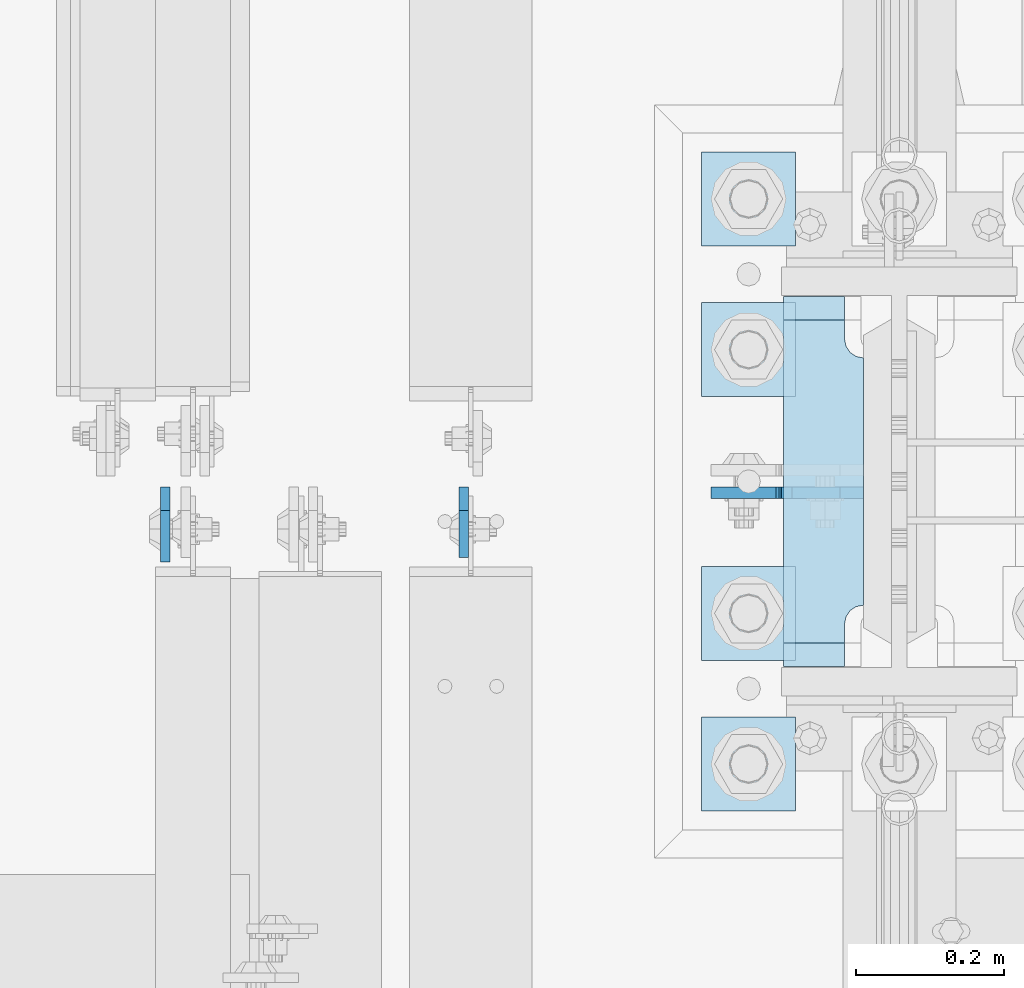
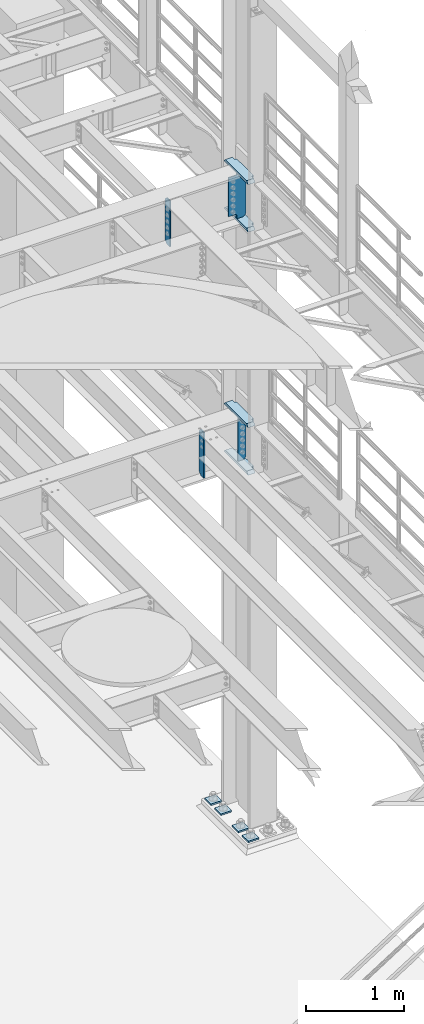
# One storey, part 1592 of 1876: 12 plates, 4 elements without a shape of their own.
"""IFC2X3 building model written with IfcOpenShell, lengths in millimetres."""

import ifcopenshell
import ifcopenshell.guid

model = None  # the IFC model being written
_history = None  # IfcOwnerHistory: only IFC2X3 demands one
_inside = {}  # id of a spatial element -> (the spatial element, [elements in it])
_under = {}  # id of a project, library or spatial element -> (it, [spatial elements below it])
_declared = {}  # id of a project -> (the project, [libraries it declares])
_typed = {}  # id of a type object -> (the type object, [elements of that type])
_made_of = {}  # id of a material, layer set ... -> (it, [elements and type objects made of it])


def new_model(schema):
    """Start an empty IFC model of exactly this schema.

    Asked for "IFC4X3", IfcOpenShell would pick the latest addendum, in which some entities
    have other attributes; the version numbers below select the first issue.
    IFC2X3 requires an IfcOwnerHistory on every rooted entity: one is made here for all.
    """
    global model, _history
    if schema == "IFC4X3":
        model = ifcopenshell.file(schema_version=(4, 3, 0, 0))
    else:
        model = ifcopenshell.file(schema=schema)
    _inside.clear()
    _under.clear()
    _declared.clear()
    _typed.clear()
    _made_of.clear()
    _history = None
    if model.schema == "IFC2X3":
        org = make("IfcOrganization", Name="unknown")
        user = make(
            "IfcPersonAndOrganization",
            ThePerson=make("IfcPerson", FamilyName="unknown"),
            TheOrganization=org,
        )
        app = make(
            "IfcApplication",
            ApplicationDeveloper=org,
            Version="unknown",
            ApplicationFullName="unknown",
            ApplicationIdentifier="unknown",
        )
        _history = make(
            "IfcOwnerHistory",
            OwningUser=user,
            OwningApplication=app,
            ChangeAction="ADDED",
            CreationDate=0,
        )
    return model


def make(cls, **values):
    """One entity of the class cls with the attributes given. An attribute that is None is left unset."""
    return model.create_entity(
        cls, **{name: value for name, value in values.items() if value is not None}
    )


def rooted(cls, **values):
    """An entity with a GlobalId (a new one), such as an element, a storey or a relation."""
    return make(cls, GlobalId=ifcopenshell.guid.new(), OwnerHistory=_history, **values)


def si_unit(unit_type, name, prefix=None):
    """IfcSIUnit, for example si_unit("LENGTHUNIT", "METRE", prefix="MILLI")."""
    return make("IfcSIUnit", UnitType=unit_type, Prefix=prefix, Name=name)


def assignment(units):
    """IfcUnitAssignment: the units of a project."""
    return None if units is None else make("IfcUnitAssignment", Units=units)


def point(xyz):
    """IfcCartesianPoint."""
    return None if xyz is None else make("IfcCartesianPoint", Coordinates=xyz)


def direction(xyz):
    """IfcDirection."""
    return None if xyz is None else make("IfcDirection", DirectionRatios=xyz)


def frame(location, z_axis=None, x_axis=None):
    """IfcAxis2Placement3D, a coordinate frame: its origin and axes. An axis left out is left unset."""
    return make(
        "IfcAxis2Placement3D",
        Location=point(location),
        Axis=direction(z_axis),
        RefDirection=direction(x_axis),
    )


def origin_with_axes():
    """The frame at (0, 0, 0) with the z axis (0, 0, 1) and the x axis (1, 0, 0) written out."""
    return frame((0.0, 0.0, 0.0), z_axis=(0.0, 0.0, 1.0), x_axis=(1.0, 0.0, 0.0))


def place(relative_to, where):
    """IfcLocalPlacement: puts the frame where relative to a parent placement (None: the world)."""
    return make(
        "IfcLocalPlacement", PlacementRelTo=relative_to, RelativePlacement=where
    )


def context(
    kind, dimensions, precision=None, world=None, true_north=None, identifier=None
):
    """IfcGeometricRepresentationContext, for example the 3D "Model" context."""
    return make(
        "IfcGeometricRepresentationContext",
        ContextIdentifier=identifier,
        ContextType=kind,
        CoordinateSpaceDimension=dimensions,
        Precision=precision,
        WorldCoordinateSystem=world,
        TrueNorth=true_north,
    )


def subcontext(parent, identifier, kind, view, scale=None):
    """IfcGeometricRepresentationSubContext, for example "Body" below "Model"."""
    return make(
        "IfcGeometricRepresentationSubContext",
        ContextIdentifier=identifier,
        ContextType=kind,
        ParentContext=parent,
        TargetScale=scale,
        TargetView=view,
    )


def project(units=None, contexts=None):
    """IfcProject with its units and contexts."""
    return rooted(
        "IfcProject",
        Name="project",
        RepresentationContexts=contexts,
        UnitsInContext=assignment(units),
    )


def spatial(cls, under=None, at=None, **own):
    """A site, building, storey or space (cls), placed at a placement, below another one or the project."""
    s = rooted(cls, ObjectPlacement=at, **own)
    if under is not None:
        _under.setdefault(under.id(), (under, []))[1].append(s)
    return s


def faces_of(points, faces, orient=None, outer=None):
    """IfcFace entities. A face is a list of loops; a loop is a list of indices into points, from 0.

    orient and outer hold one flag for each loop. By default every Orientation is true, the
    first loop of a face is its IfcFaceOuterBound and the others are IfcFaceBound.
    """
    made = []
    for i, loops in enumerate(faces):
        bounds = []
        for j, loop in enumerate(loops):
            is_outer = j == 0 if outer is None else outer[i][j]
            bounds.append(
                make(
                    "IfcFaceOuterBound" if is_outer else "IfcFaceBound",
                    Bound=make("IfcPolyLoop", Polygon=[points[k] for k in loop]),
                    Orientation=True if orient is None else orient[i][j],
                )
            )
        made.append(make("IfcFace", Bounds=bounds))
    return made


def faceted_brep(points, faces, orient=None, outer=None, voids=None):
    """IfcFacetedBrep: a solid bounded by flat faces; with voids (closed shells), ...WithVoids."""
    shared = [point(p) for p in points]
    hull = make("IfcClosedShell", CfsFaces=faces_of(shared, faces, orient, outer))
    if voids is None:
        return make("IfcFacetedBrep", Outer=hull)
    return make(
        "IfcFacetedBrepWithVoids",
        Outer=hull,
        Voids=[
            make(cls, CfsFaces=faces_of(shared, fs, o, b)) for cls, fs, o, b in voids
        ],
    )


def shape(context_of_items, identifier, shape_type, items):
    """IfcShapeRepresentation: the items that make up one representation, for example the "Body"."""
    return make(
        "IfcShapeRepresentation",
        ContextOfItems=context_of_items,
        RepresentationIdentifier=identifier,
        RepresentationType=shape_type,
        Items=items,
    )


def material(Name=None, Category=None):
    """IfcMaterial."""
    return make("IfcMaterial", Name=Name, Category=Category)


def made_of(thing, what):
    """Note that an element or type object is made of a material, layer set ...; save() writes the relation."""
    if what is not None:
        _made_of.setdefault(what.id(), (what, []))[1].append(thing)
    return thing


def type_object(cls, material=None, **own):
    """A type object (cls), such as IfcWallType, which elements share."""
    return made_of(rooted(cls, **own), material)


def element(
    cls,
    number,
    at=None,
    inside=None,
    cuts=None,
    type_object=None,
    material=None,
    context=None,
    identifier="Body",
    shape_type=None,
    held_by="IfcProductDefinitionShape",
    body=None,
    shapes=None,
    **own,
):
    """One element of the class cls, such as IfcWall. Its Tag is "e" and its number.

    at: its placement. inside: the storey or other place that contains it. cuts: it is an
    opening in that element (IfcRelVoidsElement). A single representation is given by context,
    identifier, shape_type and body (its items); several are given by shapes. held_by: the class
    of the entity that holds the representations. save() writes the other relations.
    """
    e = rooted(cls, Tag="e%d" % number, ObjectPlacement=at, **own)
    if body is not None:
        shapes = [shape(context, identifier, shape_type, body)]
    if shapes is not None:
        e.Representation = make(held_by, Representations=shapes)
    if inside is not None:
        _inside.setdefault(inside.id(), (inside, []))[1].append(e)
    if cuts is not None:
        rooted(
            "IfcRelVoidsElement", RelatingBuildingElement=cuts, RelatedOpeningElement=e
        )
    if type_object is not None:
        _typed.setdefault(type_object.id(), (type_object, []))[1].append(e)
    return made_of(e, material)


def aggregate(whole, parts):
    """IfcRelAggregates: a whole, such as a stair, and the parts it consists of."""
    return rooted("IfcRelAggregates", RelatingObject=whole, RelatedObjects=parts)


def save(model, path):
    """Write the relations noted so far, then the file.

    IfcRelAggregates (storeys below a building ...), IfcRelContainedInSpatialStructure (elements
    in a storey), IfcRelDefinesByType, IfcRelAssociatesMaterial and IfcRelDeclares: one each for
    every whole, place, type object, material and project.
    """
    for whole, parts in _under.values():
        aggregate(whole, parts)
    for where, things in _inside.values():
        rooted(
            "IfcRelContainedInSpatialStructure",
            RelatedElements=things,
            RelatingStructure=where,
        )
    for kind, things in _typed.values():
        rooted("IfcRelDefinesByType", RelatedObjects=things, RelatingType=kind)
    for what, things in _made_of.values():
        rooted("IfcRelAssociatesMaterial", RelatedObjects=things, RelatingMaterial=what)
    for by, libraries in _declared.values():
        rooted("IfcRelDeclares", RelatingContext=by, RelatedDefinitions=libraries)
    model.write(path)


model = new_model("IFC2X3")

# Units and contexts
model_context = context("Model", 3, precision=1e-05, world=origin_with_axes())
body_context = subcontext(model_context, "Body", "Model", "MODEL_VIEW")
ifc_project = project(units=[si_unit("LENGTHUNIT", "METRE", prefix="MILLI"), si_unit("AREAUNIT", "SQUARE_METRE"), si_unit("VOLUMEUNIT", "CUBIC_METRE"), si_unit("MASSUNIT", "GRAM", prefix="KILO"), si_unit("TIMEUNIT", "SECOND"), si_unit("PLANEANGLEUNIT", "RADIAN"), si_unit("SOLIDANGLEUNIT", "STERADIAN"), si_unit("THERMODYNAMICTEMPERATUREUNIT", "DEGREE_CELSIUS"), si_unit("LUMINOUSINTENSITYUNIT", "LUMEN")], contexts=[model_context])

# Site, building, storey
site_placement = place(None, origin_with_axes())
site = spatial("IfcSite", under=ifc_project, at=site_placement, CompositionType="ELEMENT")
building_placement = place(site_placement, origin_with_axes())
building = spatial("IfcBuilding", under=site, at=building_placement, Name="Undefined", CompositionType="ELEMENT")
storey_placement = place(building_placement, origin_with_axes())
storey = spatial("IfcBuildingStorey", under=building, at=storey_placement, Name="Undefined", CompositionType="ELEMENT", Elevation=0.0)

# Assembly, plate
assembly_1_placement = place(storey_placement, origin_with_axes())
assembly_1 = element("IfcElementAssembly", 1, at=assembly_1_placement, inside=storey, Name="BEAM", AssemblyPlace="NOTDEFINED", PredefinedType="RIGID_FRAME")
ifc_material_1 = material(Name="STEEL/A36")
plate_type_1 = type_object("IfcPlateType", PredefinedType="NOTDEFINED")
plate_1_placement = place(assembly_1_placement, frame((7032.62499990463, 1516.85625, 4535.4875), z_axis=(0.0, 0.0, 1.0), x_axis=(0.0, -1.0, 0.0)))
plate_1 = element("IfcPlate", 2, at=plate_1_placement, type_object=plate_type_1, material=ifc_material_1, Name="PLATE", context=body_context, shape_type="Brep", body=[
    faceted_brep([(0.0, -6.34999999999991, 31.75), (0.0, -6.35000000000036, 538.162475585938), (0.0, 6.35000000000036, 538.162475585938), (0.0, 6.34999999999991, 31.75), (31.75, -6.35000000000036, 569.912475585938), (31.75, 6.35000000000036, 569.912475585938), (95.25, -6.35000000000036, 569.912475585938), (95.25, 6.35000000000036, 569.912475585938), (95.25, -6.35000000000036, 0.0), (95.25, 6.35000000000036, 0.0), (31.75, -6.34999999999991, 0.0), (31.75, 6.34999999999991, 0.0)], [[[0, 1, 2, 3]], [[1, 4, 5, 2]], [[4, 6, 7, 5]], [[6, 8, 9, 7]], [[8, 10, 11, 9]], [[10, 0, 3, 11]], [[5, 7, 9, 11, 3, 2]], [[10, 8, 6, 4, 1, 0]]]),
])
aggregate(assembly_1, [plate_1])

assembly_2_placement = place(storey_placement, origin_with_axes())
assembly_2 = element("IfcElementAssembly", 3, at=assembly_2_placement, inside=storey, Name="BEAM", AssemblyPlace="NOTDEFINED", PredefinedType="RIGID_FRAME")
plate_type_2 = type_object("IfcPlateType", PredefinedType="NOTDEFINED")
plate_2_placement = place(assembly_2_placement, frame((6630.19374988075, 1516.85625, 7558.0875), z_axis=(0.0, 0.0, 1.0), x_axis=(0.0, -1.0, 0.0)))
plate_2 = element("IfcPlate", 4, at=plate_2_placement, type_object=plate_type_2, material=ifc_material_1, Name="PLATE", context=body_context, shape_type="Brep", body=[
    faceted_brep([(0.0, -6.34999999999991, 31.75), (0.0, -6.35000000000036, 538.162475585938), (0.0, 6.35000000000036, 538.162475585938), (0.0, 6.34999999999991, 31.75), (31.75, -6.35000000000036, 569.912475585938), (31.75, 6.35000000000036, 569.912475585938), (101.599998474121, -6.34999999999991, 569.912475585938), (101.599998474121, 6.34999999999991, 569.912475585938), (101.599998474121, -6.35000000000036, 0.0), (101.599998474121, 6.35000000000036, 0.0), (31.75, -6.34999999999991, 0.0), (31.75, 6.34999999999991, 0.0)], [[[0, 1, 2, 3]], [[1, 4, 5, 2]], [[4, 6, 7, 5]], [[6, 8, 9, 7]], [[8, 10, 11, 9]], [[10, 0, 3, 11]], [[5, 7, 9, 11, 3, 2]], [[10, 8, 6, 4, 1, 0]]]),
])
aggregate(assembly_2, [plate_2])

# Assembly, plates
assembly_3_placement = place(storey_placement, origin_with_axes())
assembly_3 = element("IfcElementAssembly", 5, at=assembly_3_placement, inside=storey, Name="COLUMN", AssemblyPlace="NOTDEFINED", PredefinedType="RIGID_FRAME")
plate_type_3 = type_object("IfcPlateType", PredefinedType="NOTDEFINED")
plate_3_placement = place(assembly_3_placement, frame((7571.58125, 1508.91949987411, 5099.05), z_axis=(-1.0, 0.0, 0.0), x_axis=(0.0, 0.0, -1.0)))
plate_3 = element("IfcPlate", 6, at=plate_3_placement, type_object=plate_type_3, material=ifc_material_1, Name="PLATE", context=body_context, shape_type="Brep", body=[
    faceted_brep([(0.0, -7.93749999999998, 31.75), (0.0, -7.9375, 96.0437469482422), (0.0, 7.9375, 96.0437469482422), (0.0, 7.93749999999999, 31.75), (558.799987792969, -7.9375, 96.0437469482422), (558.799987792969, 7.9375, 96.0437469482422), (558.799987792969, -7.93749999999998, 31.75), (558.799987792969, 7.93749999999999, 31.75), (527.049987792969, -7.93749999999998, 0.0), (527.049987792969, 7.93749999999999, 0.0), (31.75, -7.93749999999998, 0.0), (31.75, 7.93749999999999, 0.0)], [[[0, 1, 2, 3]], [[1, 4, 5, 2]], [[4, 6, 7, 5]], [[6, 8, 9, 7]], [[8, 10, 11, 9]], [[10, 0, 3, 11]], [[5, 7, 9, 11, 3, 2]], [[10, 8, 6, 4, 1, 0]]]),
])
ifc_material_2 = material(Name="STEEL/A572-50")
plate_type_4 = type_object("IfcPlateType", PredefinedType="NOTDEFINED")
plate_4_placement = place(assembly_3_placement, frame((7463.63125, 1773.2375, 7546.97501220703), z_axis=(0.0, -1.0, 0.0), x_axis=(1.0, 0.0, 0.0)))
plate_4 = element("IfcPlate", 7, at=plate_4_placement, type_object=plate_type_4, material=ifc_material_2, Name="PLATE", context=body_context, shape_type="Brep", body=[
    faceted_brep([(82.5499973297119, -15.875, 498.475006103516), (82.5499973297119, 15.875, 467.025007631571), (0.0, 15.875, 467.025007631571), (0.0, -15.875, 498.475006103516), (82.5499973297119, 15.875, 31.449998471945), (82.5499973297119, -15.875, 0.0), (0.0, -15.875, 0.0), (0.0, 15.875, 31.449998471945), (82.5499973297119, 15.875, 57.1500034332275), (82.5499973297119, -15.875, 57.1500034332275), (84.4834571748879, -15.875, 66.8701624693188), (84.4834571748879, 15.875, 66.8701624693188), (89.9894849758439, -15.875, 75.1105154056261), (89.9894849758439, 15.875, 75.1105154056261), (98.2298379121512, -15.875, 80.616543206582), (98.2298379121512, 15.875, 80.616543206582), (107.949996948242, -15.875, 82.5500030517578), (107.949996948242, 15.875, 82.5500030517578), (107.949996948242, -15.875, 415.925003051758), (107.949996948242, 15.875, 415.925003051758), (98.2298379121512, -15.875, 417.858462896934), (98.2298379121512, 15.875, 417.858462896934), (89.9894849758439, -15.875, 423.36449069789), (89.9894849758439, 15.875, 423.36449069789), (84.483457174887, -15.875, 431.604843634197), (84.483457174887, 15.875, 431.604843634197), (82.5499973297119, -15.875, 441.325002670288), (82.5499973297119, 15.875, 441.325002670288)], [[[0, 1, 2, 3]], [[4, 5, 6, 7]], [[8, 9, 5, 4]], [[10, 9, 8, 11]], [[12, 10, 11, 13]], [[14, 12, 13, 15]], [[16, 14, 15, 17]], [[18, 16, 17, 19]], [[20, 18, 19, 21]], [[22, 20, 21, 23]], [[24, 22, 23, 25]], [[26, 24, 25, 27]], [[6, 5, 9, 10, 12, 14, 16, 18, 20, 22, 24, 26, 0, 3]], [[7, 6, 3, 2]], [[27, 25, 23, 21, 19, 17, 15, 13, 11, 8, 4, 7, 2, 1]], [[26, 27, 1, 0]]]),
])
plate_5_placement = place(assembly_3_placement, frame((7463.63125, 1773.2375, 8137.525), z_axis=(0.0, -1.0, 0.0), x_axis=(1.0, 0.0, 0.0)))
plate_5 = element("IfcPlate", 8, at=plate_5_placement, type_object=plate_type_4, material=ifc_material_2, Name="PLATE", context=body_context, shape_type="Brep", body=[
    faceted_brep([(82.5499973297119, -15.875, 498.475006103516), (82.5499973297119, 15.875, 467.025007631571), (0.0, 15.875, 467.025007631571), (0.0, -15.875, 498.475006103516), (82.5499973297119, 15.875, 31.449998471945), (82.5499973297119, -15.875, 0.0), (0.0, -15.875, 0.0), (0.0, 15.875, 31.449998471945), (82.5499973297119, 15.875, 57.1500034332275), (82.5499973297119, -15.875, 57.1500034332275), (84.4834571748879, -15.875, 66.8701624693188), (84.4834571748879, 15.875, 66.8701624693188), (89.9894849758439, -15.875, 75.1105154056261), (89.9894849758439, 15.875, 75.1105154056261), (98.2298379121512, -15.875, 80.616543206582), (98.2298379121512, 15.875, 80.616543206582), (107.949996948242, -15.875, 82.5500030517578), (107.949996948242, 15.875, 82.5500030517578), (107.949996948242, -15.875, 415.925003051758), (107.949996948242, 15.875, 415.925003051758), (98.2298379121512, -15.875, 417.858462896934), (98.2298379121512, 15.875, 417.858462896934), (89.9894849758439, -15.875, 423.36449069789), (89.9894849758439, 15.875, 423.36449069789), (84.483457174887, -15.875, 431.604843634197), (84.483457174887, 15.875, 431.604843634197), (82.5499973297119, -15.875, 441.325002670288), (82.5499973297119, 15.875, 441.325002670288)], [[[0, 1, 2, 3]], [[4, 5, 6, 7]], [[8, 9, 5, 4]], [[10, 9, 8, 11]], [[12, 10, 11, 13]], [[14, 12, 13, 15]], [[16, 14, 15, 17]], [[18, 16, 17, 19]], [[20, 18, 19, 21]], [[22, 20, 21, 23]], [[24, 22, 23, 25]], [[26, 24, 25, 27]], [[6, 5, 9, 10, 12, 14, 16, 18, 20, 22, 24, 26, 0, 3]], [[7, 6, 3, 2]], [[27, 25, 23, 21, 19, 17, 15, 13, 11, 8, 4, 7, 2, 1]], [[26, 27, 1, 0]]]),
])
plate_6_placement = place(assembly_3_placement, frame((7463.63125, 1773.2375, 4524.37497558594), z_axis=(0.0, -1.0, 0.0), x_axis=(1.0, 0.0, 0.0)))
plate_6 = element("IfcPlate", 9, at=plate_6_placement, type_object=plate_type_4, material=ifc_material_2, Name="PLATE", context=body_context, shape_type="Brep", body=[
    faceted_brep([(82.5499973297119, -15.875, 498.475006103516), (82.5499973297119, 15.875, 467.025007631571), (0.0, 15.875, 467.025007631571), (0.0, -15.875, 498.475006103516), (82.5499973297119, 15.875, 31.449998471945), (82.5499973297119, -15.875, 0.0), (0.0, -15.875, 0.0), (0.0, 15.875, 31.449998471945), (82.5499973297119, 15.875, 57.1500034332275), (82.5499973297119, -15.875, 57.1500034332275), (84.4834571748879, -15.875, 66.8701624693188), (84.4834571748879, 15.875, 66.8701624693188), (89.9894849758439, -15.875, 75.1105154056261), (89.9894849758439, 15.875, 75.1105154056261), (98.2298379121512, -15.875, 80.616543206582), (98.2298379121512, 15.875, 80.616543206582), (107.949996948242, -15.875, 82.5500030517578), (107.949996948242, 15.875, 82.5500030517578), (107.949996948242, -15.875, 415.925003051758), (107.949996948242, 15.875, 415.925003051758), (98.2298379121512, -15.875, 417.858462896934), (98.2298379121512, 15.875, 417.858462896934), (89.9894849758439, -15.875, 423.36449069789), (89.9894849758439, 15.875, 423.36449069789), (84.483457174887, -15.875, 431.604843634197), (84.483457174887, 15.875, 431.604843634197), (82.5499973297119, -15.875, 441.325002670288), (82.5499973297119, 15.875, 441.325002670288)], [[[0, 1, 2, 3]], [[4, 5, 6, 7]], [[8, 9, 5, 4]], [[10, 9, 8, 11]], [[12, 10, 11, 13]], [[14, 12, 13, 15]], [[16, 14, 15, 17]], [[18, 16, 17, 19]], [[20, 18, 19, 21]], [[22, 20, 21, 23]], [[24, 22, 23, 25]], [[26, 24, 25, 27]], [[6, 5, 9, 10, 12, 14, 16, 18, 20, 22, 24, 26, 0, 3]], [[7, 6, 3, 2]], [[27, 25, 23, 21, 19, 17, 15, 13, 11, 8, 4, 7, 2, 1]], [[26, 27, 1, 0]]]),
])
plate_7_placement = place(assembly_3_placement, frame((7463.63125, 1773.2375, 5114.925), z_axis=(0.0, -1.0, 0.0), x_axis=(1.0, 0.0, 0.0)))
plate_7 = element("IfcPlate", 10, at=plate_7_placement, type_object=plate_type_4, material=ifc_material_2, Name="PLATE", context=body_context, shape_type="Brep", body=[
    faceted_brep([(82.5499973297119, -15.875, 498.475006103516), (82.5499973297119, 15.875, 467.025007631571), (0.0, 15.875, 467.025007631571), (0.0, -15.875, 498.475006103516), (82.5499973297119, 15.875, 31.449998471945), (82.5499973297119, -15.875, 0.0), (0.0, -15.875, 0.0), (0.0, 15.875, 31.449998471945), (82.5499973297119, 15.875, 57.1500034332275), (82.5499973297119, -15.875, 57.1500034332275), (84.4834571748879, -15.875, 66.8701624693188), (84.4834571748879, 15.875, 66.8701624693188), (89.9894849758439, -15.875, 75.1105154056261), (89.9894849758439, 15.875, 75.1105154056261), (98.2298379121512, -15.875, 80.616543206582), (98.2298379121512, 15.875, 80.616543206582), (107.949996948242, -15.875, 82.5500030517578), (107.949996948242, 15.875, 82.5500030517578), (107.949996948242, -15.875, 415.925003051758), (107.949996948242, 15.875, 415.925003051758), (98.2298379121512, -15.875, 417.858462896934), (98.2298379121512, 15.875, 417.858462896934), (89.9894849758439, -15.875, 423.36449069789), (89.9894849758439, 15.875, 423.36449069789), (84.483457174887, -15.875, 431.604843634197), (84.483457174887, 15.875, 431.604843634197), (82.5499973297119, -15.875, 441.325002670288), (82.5499973297119, 15.875, 441.325002670288)], [[[0, 1, 2, 3]], [[4, 5, 6, 7]], [[8, 9, 5, 4]], [[10, 9, 8, 11]], [[12, 10, 11, 13]], [[14, 12, 13, 15]], [[16, 14, 15, 17]], [[18, 16, 17, 19]], [[20, 18, 19, 21]], [[22, 20, 21, 23]], [[24, 22, 23, 25]], [[26, 24, 25, 27]], [[6, 5, 9, 10, 12, 14, 16, 18, 20, 22, 24, 26, 0, 3]], [[7, 6, 3, 2]], [[27, 25, 23, 21, 19, 17, 15, 13, 11, 8, 4, 7, 2, 1]], [[26, 27, 1, 0]]]),
])
plate_type_5 = type_object("IfcPlateType", PredefinedType="NOTDEFINED")
plate_8_placement = place(assembly_3_placement, frame((7571.58125, 1508.91875, 8121.65), z_axis=(-1.0, 0.0, 0.0), x_axis=(0.0, 0.0, -1.0)))
plate_8 = element("IfcPlate", 11, at=plate_8_placement, type_object=plate_type_5, material=ifc_material_1, Name="PLATE", context=body_context, shape_type="Brep", body=[
    faceted_brep([(501.650012207032, -7.9375, 205.581252728631), (501.650012207032, -7.9375, 123.031246757509), (501.650012207032, 7.9375, 123.031246757509), (501.650012207032, 7.9375, 205.581253051758), (502.61674212962, -7.9375, 118.171167239463), (502.61674212962, 7.9375, 118.171167239463), (505.369756030097, -7.9375, 114.050990771309), (505.369756030097, 7.9375, 114.050990771309), (509.489932498251, -7.9375, 111.297976870831), (509.489932498251, 7.9375, 111.297976870831), (514.350012016297, -7.9375, 110.331246948243), (514.350012016297, 7.9375, 110.331246948243), (558.799987792969, -7.9375, 110.331246948243), (558.799987792969, 7.9375, 110.331246948243), (19.0499992370605, -7.9375, 205.58125), (19.0499992370605, 7.9375, 205.581253051758), (19.0499992370605, 7.9375, 123.031249809265), (19.0499992370605, -7.9375, 123.031249809265), (18.083269314473, 7.9375, 118.17117029122), (18.083269314473, -7.9375, 118.17117029122), (15.3302554139955, 7.9375, 114.050993823066), (15.3302554139955, -7.9375, 114.050993823066), (11.2100789458418, 7.9375, 111.297979922588), (11.2100789458418, -7.9375, 111.297979922588), (6.34999942779541, 7.9375, 110.33125), (6.34999942779541, -7.9375, 110.33125), (0.0, 7.9375, 110.33125), (0.0, -7.9375, 110.33125), (0.0, 7.93749999999999, 31.75), (0.0, -7.93749999999998, 31.75), (31.75, -7.93749999999998, 0.0), (31.75, 7.93749999999999, 0.0), (527.049987792969, -7.93749999999998, 0.0), (527.049987792969, 7.93749999999999, 0.0), (558.799987792969, -7.93749999999998, 31.75), (558.799987792969, 7.93749999999999, 31.75)], [[[0, 1, 2, 3]], [[4, 5, 2, 1]], [[6, 7, 5, 4]], [[8, 9, 7, 6]], [[10, 11, 9, 8]], [[12, 13, 11, 10]], [[14, 15, 16, 17]], [[17, 16, 18, 19]], [[19, 18, 20, 21]], [[21, 20, 22, 23]], [[23, 22, 24, 25]], [[25, 24, 26, 27]], [[28, 29, 27, 26]], [[30, 29, 28, 31]], [[32, 30, 31, 33]], [[34, 32, 33, 35]], [[8, 6, 4, 1, 0, 14, 17, 19, 21, 23, 25, 27, 29, 30, 32, 34, 12, 10]], [[15, 14, 0, 3]], [[35, 33, 31, 28, 26, 24, 22, 20, 18, 16, 15, 3, 2, 5, 7, 9, 11, 13]], [[34, 35, 13, 12]]]),
])
aggregate(assembly_3, [plate_4, plate_5, plate_8, plate_6, plate_7, plate_3])

assembly_4_placement = place(storey_placement, origin_with_axes())
assembly_4 = element("IfcElementAssembly", 12, at=assembly_4_placement, inside=storey, Name="TEMPLATE", AssemblyPlace="NOTDEFINED", PredefinedType="RIGID_FRAME")
plate_type_6 = type_object("IfcPlateType", PredefinedType="NOTDEFINED")
plate_9_placement = place(assembly_4_placement, frame((7480.3, 1206.5, 104.775), z_axis=(-1.0, 0.0, 0.0), x_axis=(0.0, -1.0, 0.0)))
plate_9 = element("IfcPlate", 13, at=plate_9_placement, type_object=plate_type_6, material=ifc_material_2, Name="PLATE WASHER", context=body_context, shape_type="Brep", body=[
    faceted_brep([(-9.09494701772928e-13, -9.525, -1.81898940354586e-12), (0.0, -9.52500000000001, 127.0), (0.0, 9.52500000000001, 127.0), (-9.09494701772928e-13, 9.525, -1.81898940354586e-12), (127.0, -9.52500000000001, 127.0), (127.0, 9.52500000000001, 127.0), (127.0, -9.52500000000001, 0.0), (127.0, 9.52500000000001, 0.0)], [[[0, 1, 2, 3]], [[1, 4, 5, 2]], [[4, 6, 7, 5]], [[6, 0, 3, 7]], [[5, 7, 3, 2]], [[6, 4, 1, 0]]]),
])
plate_10_placement = place(assembly_4_placement, frame((7480.3, 1409.7, 104.775), z_axis=(-1.0, 0.0, 0.0), x_axis=(0.0, -1.0, 0.0)))
plate_10 = element("IfcPlate", 14, at=plate_10_placement, type_object=plate_type_6, material=ifc_material_2, Name="PLATE WASHER", context=body_context, shape_type="Brep", body=[
    faceted_brep([(-9.09494701772928e-13, -9.525, -1.81898940354586e-12), (0.0, -9.52500000000001, 127.0), (0.0, 9.52500000000001, 127.0), (-9.09494701772928e-13, 9.525, -1.81898940354586e-12), (127.0, -9.52500000000001, 127.0), (127.0, 9.52500000000001, 127.0), (127.0, -9.52500000000001, 0.0), (127.0, 9.52500000000001, 0.0)], [[[0, 1, 2, 3]], [[1, 4, 5, 2]], [[4, 6, 7, 5]], [[6, 0, 3, 7]], [[5, 7, 3, 2]], [[6, 4, 1, 0]]]),
])
plate_11_placement = place(assembly_4_placement, frame((7480.3, 1765.3, 104.775), z_axis=(-1.0, 0.0, 0.0), x_axis=(0.0, -1.0, 0.0)))
plate_11 = element("IfcPlate", 15, at=plate_11_placement, type_object=plate_type_6, material=ifc_material_2, Name="PLATE WASHER", context=body_context, shape_type="Brep", body=[
    faceted_brep([(-9.09494701772928e-13, -9.525, -1.81898940354586e-12), (0.0, -9.52500000000001, 127.0), (0.0, 9.52500000000001, 127.0), (-9.09494701772928e-13, 9.525, -1.81898940354586e-12), (127.0, -9.52500000000001, 127.0), (127.0, 9.52500000000001, 127.0), (127.0, -9.52500000000001, 0.0), (127.0, 9.52500000000001, 0.0)], [[[0, 1, 2, 3]], [[1, 4, 5, 2]], [[4, 6, 7, 5]], [[6, 0, 3, 7]], [[5, 7, 3, 2]], [[6, 4, 1, 0]]]),
])
plate_12_placement = place(assembly_4_placement, frame((7480.3, 1968.5, 104.775), z_axis=(-1.0, 0.0, 0.0), x_axis=(0.0, -1.0, 0.0)))
plate_12 = element("IfcPlate", 16, at=plate_12_placement, type_object=plate_type_6, material=ifc_material_2, Name="PLATE WASHER", context=body_context, shape_type="Brep", body=[
    faceted_brep([(-9.09494701772928e-13, -9.525, -1.81898940354586e-12), (0.0, -9.52500000000001, 127.0), (0.0, 9.52500000000001, 127.0), (-9.09494701772928e-13, 9.525, -1.81898940354586e-12), (127.0, -9.52500000000001, 127.0), (127.0, 9.52500000000001, 127.0), (127.0, -9.52500000000001, 0.0), (127.0, 9.52500000000001, 0.0)], [[[0, 1, 2, 3]], [[1, 4, 5, 2]], [[4, 6, 7, 5]], [[6, 0, 3, 7]], [[5, 7, 3, 2]], [[6, 4, 1, 0]]]),
])
aggregate(assembly_4, [plate_9, plate_10, plate_11, plate_12])

save(model, "model.ifc")
